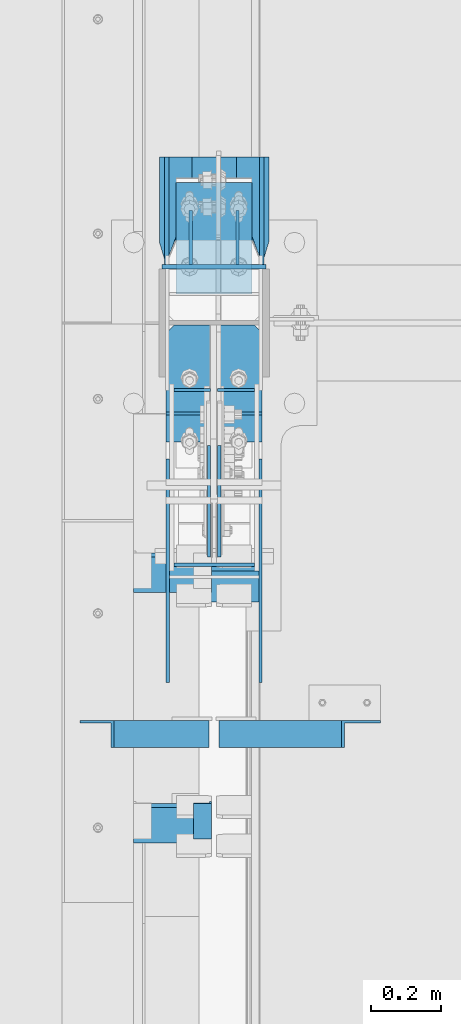
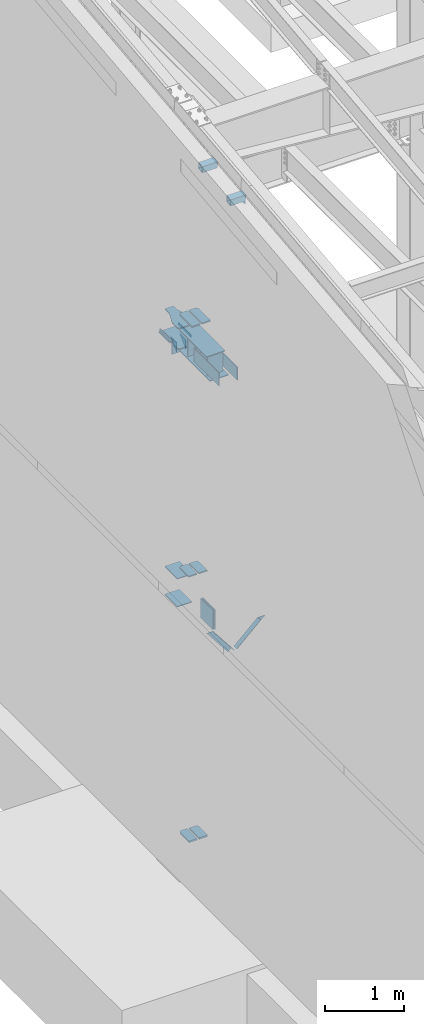
# One storey, part 827 of 1179: 27 beams, 2 members, 13 elements without a shape of their own.
"""IFC2X3 building model written with IfcOpenShell, lengths in millimetres."""

from ifc_helpers import new_model, si_unit, frame, origin_with_axes, place, context, subcontext, project, spatial, faceted_brep, material, type_object, element, aggregate, save


model = new_model("IFC2X3")

# Units and contexts
model_context = context("Model", 3, precision=1e-05, world=origin_with_axes())
body_context = subcontext(model_context, "Body", "Model", "MODEL_VIEW")
ifc_project = project(units=[si_unit("LENGTHUNIT", "METRE", prefix="MILLI"), si_unit("AREAUNIT", "SQUARE_METRE"), si_unit("VOLUMEUNIT", "CUBIC_METRE"), si_unit("MASSUNIT", "GRAM", prefix="KILO"), si_unit("TIMEUNIT", "SECOND"), si_unit("PLANEANGLEUNIT", "RADIAN"), si_unit("SOLIDANGLEUNIT", "STERADIAN"), si_unit("THERMODYNAMICTEMPERATUREUNIT", "DEGREE_CELSIUS"), si_unit("LUMINOUSINTENSITYUNIT", "LUMEN")], contexts=[model_context])

# Site, building, storey
site_placement = place(None, origin_with_axes())
site = spatial("IfcSite", under=ifc_project, at=site_placement, CompositionType="ELEMENT")
building_placement = place(site_placement, origin_with_axes())
building = spatial("IfcBuilding", under=site, at=building_placement, Name="Undefined", CompositionType="ELEMENT")
storey_placement = place(building_placement, origin_with_axes())
storey = spatial("IfcBuildingStorey", under=building, at=storey_placement, Name="Undefined", CompositionType="ELEMENT", Elevation=0.0)

# Assembly, member
assembly_1_placement = place(storey_placement, origin_with_axes())
assembly_1 = element("IfcElementAssembly", 1, at=assembly_1_placement, inside=storey, Name="ANGLE", AssemblyPlace="NOTDEFINED", PredefinedType="RIGID_FRAME")
ifc_material_1 = material(Name="STEEL/A36")
member_type = type_object("IfcMemberType", Name="L3X3X1/4", PredefinedType="NOTDEFINED")
member_1_placement = place(assembly_1_placement, frame((472.414639168564, 18059.4, 3736.19330123132), z_axis=(0.0, -1.0, 0.0), x_axis=(0.729484494811633, 0.0, 0.683997347823379)))
member_1 = element("IfcMember", 2, at=member_1_placement, type_object=member_type, material=ifc_material_1, Name="ANGLE", ObjectType="L3X3X1/4", context=body_context, shape_type="Brep", body=[
    faceted_brep([(0.0, 38.0999999999985, -38.0999999999999), (0.0, 38.0999999999985, 38.0999999999999), (475.752341075195, 38.0999999999181, 38.1000000000004), (475.752341075195, 38.0999999999181, -38.1000000000004), (0.0, 31.75, 38.1000000000004), (482.524628360803, 31.7499999999177, 38.1000000000004), (0.0, 31.75, -31.75), (482.524628360803, 31.7499999999177, -31.75), (0.0, -38.0999999999985, -31.75), (557.019788502486, -38.1000000000854, -31.75), (0.0, -38.0999999999985, -38.0999999999999), (557.019788502486, -38.1000000000854, -38.1000000000004)], [[[0, 1, 2, 3]], [[1, 4, 5, 2]], [[4, 6, 7, 5]], [[6, 8, 9, 7]], [[8, 10, 11, 9]], [[10, 0, 3, 11]], [[5, 7, 9, 11, 3, 2]], [[10, 8, 6, 4, 1, 0]]]),
])
aggregate(assembly_1, [member_1])

assembly_2_placement = place(storey_placement, origin_with_axes())
assembly_2 = element("IfcElementAssembly", 3, at=assembly_2_placement, inside=storey, Name="ANGLE", AssemblyPlace="NOTDEFINED", PredefinedType="RIGID_FRAME")
member_2_placement = place(assembly_2_placement, frame((80.8196258456476, 18059.4, 4125.56128839178), z_axis=(0.0, -1.0, 0.0), x_axis=(0.614083067285056, 0.0, -0.789241399366364)))
member_2 = element("IfcMember", 4, at=member_2_placement, type_object=member_type, material=ifc_material_1, Name="ANGLE", ObjectType="L3X3X1/4", context=body_context, shape_type="Brep", body=[
    faceted_brep([(59.3707492954454, 38.0999999999781, -38.1000000000004), (59.3707492954454, 38.0999999999781, 38.1000000000004), (499.083854779058, 38.0999999998585, 38.1000000000004), (499.083854779058, 38.0999999998585, -38.1000000000004), (54.4300207928691, 31.7499999999804, 38.1000000000004), (499.083854779056, 31.7499999998595, 38.1000000000004), (54.4300207928691, 31.7499999999804, -31.75), (499.083854779056, 31.7499999998595, -31.75), (0.0820072645328764, -38.0999999999945, -31.75), (499.083854779043, -38.10000000013, -31.75), (0.0820072645328764, -38.0999999999945, -38.1000000000004), (499.083854779043, -38.10000000013, -38.1000000000004)], [[[0, 1, 2, 3]], [[1, 4, 5, 2]], [[4, 6, 7, 5]], [[6, 8, 9, 7]], [[8, 10, 11, 9]], [[10, 0, 3, 11]], [[5, 7, 9, 11, 3, 2]], [[10, 8, 6, 4, 1, 0]]]),
])
aggregate(assembly_2, [member_2])

# Assembly, beams
assembly_3_placement = place(storey_placement, origin_with_axes())
assembly_3 = element("IfcElementAssembly", 5, at=assembly_3_placement, inside=storey, Name="COLUMN", AssemblyPlace="NOTDEFINED", PredefinedType="RIGID_FRAME")
beam_type_1 = type_object("IfcBeamType", PredefinedType="NOTDEFINED")
beam_1_placement = place(assembly_3_placement, frame((284.162500000006, 19388.1375, 7616.82500000912), z_axis=(0.0, 0.0, 1.0), x_axis=(1.0, 0.0, 0.0)))
beam_1 = element("IfcBeam", 6, at=beam_1_placement, type_object=beam_type_1, material=ifc_material_1, Name="PLATE", context=body_context, shape_type="Brep", body=[
    faceted_brep([(-7.27595761418343e-12, 6.35000000000036, -76.1999999999971), (0.0, 6.35000000000036, 76.2000000000044), (295.274999999994, 6.34999999999854, 76.2000000000007), (295.274999999994, 6.34999999999854, -76.2000000000007), (0.0, -6.35000000000036, 76.2000000000044), (295.274999999994, -6.34999999999854, 76.2000000000007), (7.27595761418343e-12, -6.35000000000036, -76.1999999999971), (295.274999999994, -6.34999999999854, -76.2000000000007)], [[[0, 1, 2, 3]], [[1, 4, 5, 2]], [[4, 6, 7, 5]], [[6, 0, 3, 7]], [[5, 7, 3, 2]], [[6, 4, 1, 0]]]),
])
ifc_material_2 = material(Name="STEEL/A572-GR.50")
beam_type_2 = type_object("IfcBeamType", PredefinedType="NOTDEFINED")
beam_2_placement = place(assembly_3_placement, frame((505.619000000002, 18974.0139016459, 4353.49928057188), z_axis=(1.0, 0.0, 0.0), x_axis=(0.0, 1.0, 0.0)))
beam_2 = element("IfcBeam", 7, at=beam_2_placement, type_object=beam_type_2, material=ifc_material_2, Name="PLATE", context=body_context, shape_type="Brep", body=[
    faceted_brep([(247.436098354521, -9.52499999999964, 40.4809996181785), (247.436098354145, 9.52499999999964, 40.4809996181785), (225.211098339509, 9.52499999999964, 62.7065000000002), (225.211098339509, -9.52499999999964, 62.7065000000002), (6.18456397205591e-11, -9.52499999999964, -62.7065000000084), (0.0, -9.52499999999964, 62.7065000000002), (0.0, 9.52499999999964, 62.7065000000002), (6.18456397205591e-11, 9.52499999999964, -62.7065000000084), (247.436098339509, 9.52499999999964, -62.7065000000002), (247.436098339509, -9.52499999999964, -62.7065000000002)], [[[0, 1, 2, 3]], [[4, 5, 6, 7]], [[4, 7, 8, 9]], [[5, 4, 9, 0, 3]], [[6, 5, 3, 2]], [[8, 7, 6, 2, 1]], [[9, 8, 1, 0]]]),
])
beam_3_placement = place(assembly_3_placement, frame((357.981000000002, 18974.0139016459, 4353.49928057188), z_axis=(-1.0, 0.0, 0.0), x_axis=(0.0, 1.0, 0.0)))
beam_3 = element("IfcBeam", 8, at=beam_3_placement, type_object=beam_type_2, material=ifc_material_2, Name="PLATE", context=body_context, shape_type="Brep", body=[
    faceted_brep([(247.436098354521, -9.52499999999964, 40.4809996181785), (247.436098354145, 9.52499999999964, 40.4809996181785), (225.211098339509, 9.52499999999964, 62.7065000000002), (225.211098339509, -9.52499999999964, 62.7065000000002), (6.18456397205591e-11, -9.52499999999964, -62.7065000000084), (0.0, -9.52499999999964, 62.7065000000002), (0.0, 9.52499999999964, 62.7065000000002), (6.18456397205591e-11, 9.52499999999964, -62.7065000000084), (247.436098339509, 9.52499999999964, -62.7065000000002), (247.436098339509, -9.52499999999964, -62.7065000000002)], [[[0, 1, 2, 3]], [[4, 5, 6, 7]], [[4, 7, 8, 9]], [[5, 4, 9, 0, 3]], [[6, 5, 3, 2]], [[8, 7, 6, 2, 1]], [[9, 8, 1, 0]]]),
])
beam_type_3 = type_object("IfcBeamType", PredefinedType="NOTDEFINED")
beam_4_placement = place(assembly_3_placement, frame((431.800000000001, 19310.35, 3676.65), z_axis=(1.0, 0.0, 0.0), x_axis=(0.0, 1.0, 0.0)))
beam_4 = element("IfcBeam", 9, at=beam_4_placement, type_object=beam_type_3, material=ifc_material_2, Name="PLATE", context=body_context, shape_type="Brep", body=[
    faceted_brep([(0.0, 6.35000000000036, -107.949999999997), (0.0, 6.35000000000036, 107.949999999997), (317.5, 6.35000000000036, 107.949999999997), (317.5, 6.35000000000036, -107.949999999997), (0.0, -6.35000000000036, 107.949999999997), (317.5, -6.35000000000036, 107.949999999997), (0.0, -6.35000000000036, -107.949999999997), (317.5, -6.35000000000036, -107.949999999997)], [[[0, 1, 2, 3]], [[1, 4, 5, 2]], [[4, 6, 7, 5]], [[6, 0, 3, 7]], [[5, 7, 3, 2]], [[6, 4, 1, 0]]]),
])
beam_5_placement = place(assembly_3_placement, frame((431.800000000001, 19310.35, 4108.45), z_axis=(1.0, 0.0, 0.0), x_axis=(0.0, 1.0, 0.0)))
beam_5 = element("IfcBeam", 10, at=beam_5_placement, type_object=beam_type_3, material=ifc_material_2, Name="PLATE", context=body_context, shape_type="Brep", body=[
    faceted_brep([(0.0, 6.35000000000036, -107.949999999997), (0.0, 6.35000000000036, 107.949999999997), (317.5, 6.35000000000036, 107.949999999997), (317.5, 6.35000000000036, -107.949999999997), (0.0, -6.35000000000036, 107.949999999997), (317.5, -6.35000000000036, 107.949999999997), (0.0, -6.35000000000036, -107.949999999997), (317.5, -6.35000000000036, -107.949999999997)], [[[0, 1, 2, 3]], [[1, 4, 5, 2]], [[4, 6, 7, 5]], [[6, 0, 3, 7]], [[5, 7, 3, 2]], [[6, 4, 1, 0]]]),
])

# Assembly, beam
assembly_4_placement = place(storey_placement, origin_with_axes())
assembly_4 = element("IfcElementAssembly", 11, at=assembly_4_placement, inside=storey, Name="BEAM", AssemblyPlace="NOTDEFINED", PredefinedType="RIGID_FRAME")
beam_type_4 = type_object("IfcBeamType", Name="L2X2X1/4", PredefinedType="NOTDEFINED")
beam_6_placement = place(assembly_4_placement, frame((399.256249999966, 17864.9694884529, 10830.0669268878), z_axis=(-1.0, 0.0, 0.0), x_axis=(0.0, -0.993676146336441, -0.112284087038017)))
beam_6 = element("IfcBeam", 12, at=beam_6_placement, type_object=beam_type_4, material=ifc_material_1, Name="ANGLE", ObjectType="L2X2X1/4", context=body_context, shape_type="Brep", body=[
    faceted_brep([(0.0, 25.3999999999996, -25.4000000000015), (0.0, 25.3999999999996, 25.4000000000015), (101.599999999555, 25.4, 25.3999999999451), (101.599999999537, 25.4, -25.4000000000251), (7.27595761418343e-12, 19.05, 25.3999999999851), (101.599999999555, 19.05, 25.3999999999451), (0.0, 19.0499992350015, -19.0499992349996), (101.600003324515, 19.0499992350051, -19.0499992350015), (-1.09139364212751e-11, -25.4, -19.0499999999865), (101.59999999954, -25.4, -19.0500000000302), (0.0, -25.3999999999996, -25.4000000000015), (101.599999999537, -25.4, -25.4000000000251)], [[[0, 1, 2, 3]], [[1, 4, 5, 2]], [[4, 6, 7, 5]], [[6, 8, 9, 7]], [[8, 10, 11, 9]], [[10, 0, 3, 11]], [[5, 7, 9, 11, 3, 2]], [[10, 8, 6, 4, 1, 0]]]),
])
aggregate(assembly_4, [beam_6])

# Beam
beam_type_5 = type_object("IfcBeamType", PredefinedType="NOTDEFINED")
beam_7_placement = place(assembly_3_placement, frame((358.775000000002, 18888.9023695225, 8262.24369604468), z_axis=(-1.0, 0.0, 0.0), x_axis=(0.0, 1.0, 0.0)))
beam_7 = element("IfcBeam", 13, at=beam_7_placement, type_object=beam_type_5, material=ifc_material_2, Name="PLATE", context=body_context, shape_type="Brep", body=[
    faceted_brep([(332.547630477533, 9.52499999999964, 41.2750000000015), (310.322630477534, 9.52499999999964, 63.5), (310.322630477534, -9.52499999999964, 63.5), (332.547630477533, -9.52499999999964, 41.2750000000015), (332.547630477533, 9.52499999999964, -63.5), (0.0, 9.52500000000146, -63.5), (0.0, 9.52500000000146, 63.5), (0.0, -9.52500000000146, 63.5), (0.0, -9.52500000000146, -63.5), (332.547630477533, -9.52499999999964, -63.5)], [[[0, 1, 2, 3]], [[4, 5, 6, 1, 0]], [[6, 7, 2, 1]], [[7, 8, 9, 3, 2]], [[8, 5, 4, 9]], [[9, 4, 0, 3]], [[8, 7, 6, 5]]]),
])

beam_8_placement = place(assembly_3_placement, frame((504.825000000002, 18888.9023695225, 8262.24369604468), z_axis=(-1.0, 0.0, 0.0), x_axis=(0.0, 1.0, 0.0)))
beam_8 = element("IfcBeam", 14, at=beam_8_placement, type_object=beam_type_5, material=ifc_material_2, Name="PLATE", context=body_context, shape_type="Brep", body=[
    faceted_brep([(310.322630477534, 9.52499999999964, -63.5), (332.547630477533, 9.52499999999964, -41.2750000000015), (332.547630477533, -9.52499999999964, -41.2750000000015), (310.322630477534, -9.52499999999964, -63.5), (0.0, 9.52500000000146, -63.5), (0.0, 9.52500000000146, 63.5), (332.547630477533, 9.52499999999964, 63.5), (0.0, -9.52500000000146, 63.5), (332.547630477533, -9.52499999999964, 63.5), (0.0, -9.52500000000146, -63.5)], [[[0, 1, 2, 3]], [[4, 5, 6, 1, 0]], [[5, 7, 8, 6]], [[8, 7, 9, 3, 2]], [[9, 4, 0, 3]], [[6, 8, 2, 1]], [[9, 7, 5, 4]]]),
])

# Assembly, beam
assembly_5_placement = place(storey_placement, origin_with_axes())
assembly_5 = element("IfcElementAssembly", 15, at=assembly_5_placement, inside=storey, Name="PLATE", AssemblyPlace="NOTDEFINED", PredefinedType="RIGID_FRAME")
beam_type_6 = type_object("IfcBeamType", PredefinedType="NOTDEFINED")
beam_9_placement = place(assembly_5_placement, frame((563.562500000004, 18840.6248035139, 7861.3), z_axis=(0.0, 0.0, 1.0), x_axis=(0.0, -1.0, 0.0)))
beam_9 = element("IfcBeam", 16, at=beam_9_placement, type_object=beam_type_6, material=ifc_material_2, Name="PLATE", context=body_context, shape_type="Brep", body=[
    faceted_brep([(0.0, 4.76250000000073, -101.6), (0.0, 4.76250000000073, 101.6), (635.0, 4.76250000000073, 101.6), (635.0, 4.76250000000073, -101.6), (0.0, -4.76250000000073, 101.6), (635.0, -4.76250000000073, 101.6), (0.0, -4.76250000000073, -101.6), (635.0, -4.76250000000073, -101.6)], [[[0, 1, 2, 3]], [[1, 4, 5, 2]], [[4, 6, 7, 5]], [[6, 0, 3, 7]], [[5, 7, 3, 2]], [[6, 4, 1, 0]]]),
])
aggregate(assembly_5, [beam_9])

assembly_6_placement = place(storey_placement, origin_with_axes())
assembly_6 = element("IfcElementAssembly", 17, at=assembly_6_placement, inside=storey, Name="PLATE", AssemblyPlace="NOTDEFINED", PredefinedType="RIGID_FRAME")
beam_10_placement = place(assembly_6_placement, frame((300.037500000002, 18840.6248035139, 7861.3), z_axis=(0.0, 0.0, 1.0), x_axis=(0.0, -1.0, 0.0)))
beam_10 = element("IfcBeam", 18, at=beam_10_placement, type_object=beam_type_6, material=ifc_material_2, Name="PLATE", context=body_context, shape_type="Brep", body=[
    faceted_brep([(0.0, 4.76250000000073, -101.6), (0.0, 4.76250000000073, 101.6), (635.0, 4.76250000000073, 101.6), (635.0, 4.76250000000073, -101.6), (0.0, -4.76250000000073, 101.6), (635.0, -4.76250000000073, 101.6), (0.0, -4.76250000000073, -101.6), (635.0, -4.76250000000073, -101.6)], [[[0, 1, 2, 3]], [[1, 4, 5, 2]], [[4, 6, 7, 5]], [[6, 0, 3, 7]], [[5, 7, 3, 2]], [[6, 4, 1, 0]]]),
])
aggregate(assembly_6, [beam_10])

# Beam
beam_type_7 = type_object("IfcBeamType", PredefinedType="NOTDEFINED")
beam_11_placement = place(assembly_3_placement, frame((317.5, 18540.5873035139, 7861.3), z_axis=(0.0, 0.0, 1.0), x_axis=(1.0, 0.0, 0.0)))
beam_11 = element("IfcBeam", 19, at=beam_11_placement, type_object=beam_type_7, material=ifc_material_2, Name="PLATE", context=body_context, shape_type="Brep", body=[
    faceted_brep([(0.0, 4.76250000000073, -152.4), (0.0, 4.76250000000073, 152.4), (228.600000000002, 4.76250000000073, 152.4), (228.600000000002, 4.76250000000073, -152.4), (0.0, -4.76250000000073, 152.4), (228.600000000002, -4.76250000000073, 152.4), (0.0, -4.76250000000073, -152.4), (228.600000000002, -4.76250000000073, -152.4)], [[[0, 1, 2, 3]], [[1, 4, 5, 2]], [[4, 6, 7, 5]], [[6, 0, 3, 7]], [[5, 7, 3, 2]], [[6, 4, 1, 0]]]),
])

beam_type_8 = type_object("IfcBeamType", PredefinedType="NOTDEFINED")
beam_12_placement = place(assembly_3_placement, frame((441.325000000002, 19037.3, 7861.3), z_axis=(0.0, 0.0, 1.0), x_axis=(1.0, 0.0, 0.0)))
beam_12 = element("IfcBeam", 20, at=beam_12_placement, type_object=beam_type_8, material=ifc_material_2, Name="PLATE", context=body_context, shape_type="Brep", body=[
    faceted_brep([(0.0, 4.76250000000073, -152.4), (0.0, 4.76250000000073, 152.4), (104.775000000001, 4.76250000000073, 152.4), (104.775000000001, 4.76250000000073, -152.4), (0.0, -4.76250000000073, 152.4), (104.775000000001, -4.76250000000073, 152.4), (0.0, -4.76250000000073, -152.4), (104.775000000001, -4.76250000000073, -152.4)], [[[0, 1, 2, 3]], [[1, 4, 5, 2]], [[4, 6, 7, 5]], [[6, 0, 3, 7]], [[5, 7, 3, 2]], [[6, 4, 1, 0]]]),
])

beam_13_placement = place(assembly_3_placement, frame((317.500000000001, 19037.3, 7861.3), z_axis=(0.0, 0.0, 1.0), x_axis=(1.0, 0.0, 0.0)))
beam_13 = element("IfcBeam", 21, at=beam_13_placement, type_object=beam_type_8, material=ifc_material_2, Name="PLATE", context=body_context, shape_type="Brep", body=[
    faceted_brep([(0.0, 4.76250000000073, -152.4), (0.0, 4.76250000000073, 152.4), (104.775000000001, 4.76250000000073, 152.4), (104.775000000001, 4.76250000000073, -152.4), (0.0, -4.76250000000073, 152.4), (104.775000000001, -4.76250000000073, 152.4), (0.0, -4.76250000000073, -152.4), (104.775000000001, -4.76250000000073, -152.4)], [[[0, 1, 2, 3]], [[1, 4, 5, 2]], [[4, 6, 7, 5]], [[6, 0, 3, 7]], [[5, 7, 3, 2]], [[6, 4, 1, 0]]]),
])

beam_type_9 = type_object("IfcBeamType", PredefinedType="NOTDEFINED")
beam_14_placement = place(assembly_3_placement, frame((431.799999999999, 18434.2248035139, 7702.55), z_axis=(-1.0, 0.0, 0.0), x_axis=(0.0, 1.0, 0.0)))
beam_14 = element("IfcBeam", 22, at=beam_14_placement, type_object=beam_type_9, material=ifc_material_2, Name="PLATE", context=body_context, shape_type="Brep", body=[
    faceted_brep([(765.000197461464, 6.35000000000036, -136.525000000001), (787.225197461465, 6.35000000000036, -114.299999999999), (787.225197461465, -6.35000000000036, -114.299999999999), (765.000197461464, -6.35000000000036, -136.525000000001), (787.225197461465, 6.35000000000036, 114.299999999999), (765.000197461464, 6.35000000000036, 136.525000000001), (765.000197461464, -6.35000000000036, 136.525000000001), (787.225197461465, -6.35000000000036, 114.299999999999), (0.0, 6.35000000000036, -136.525000000001), (0.0, 6.35000000000036, 136.525000000001), (0.0, -6.35000000000036, 136.525000000001), (0.0, -6.35000000000036, -136.525000000001)], [[[0, 1, 2, 3]], [[4, 5, 6, 7]], [[8, 9, 5, 4, 1, 0]], [[9, 10, 6, 5]], [[7, 6, 10, 11, 3, 2]], [[11, 8, 0, 3]], [[4, 7, 2, 1]], [[11, 10, 9, 8]]]),
])

beam_15_placement = place(assembly_3_placement, frame((431.799999999999, 18523.1248035139, 8020.05), z_axis=(-1.0, 0.0, 0.0), x_axis=(0.0, 1.0, 0.0)))
beam_15 = element("IfcBeam", 23, at=beam_15_placement, type_object=beam_type_9, material=ifc_material_2, Name="PLATE", context=body_context, shape_type="Brep", body=[
    faceted_brep([(676.100197461472, 6.35000000000036, -136.525000000001), (698.325197461472, 6.35000000000036, -114.299999999999), (698.325197461472, -6.35000000000036, -114.299999999999), (676.100197461472, -6.35000000000036, -136.525000000001), (698.325197461472, 6.35000000000036, 114.299999999999), (676.100197461472, 6.35000000000036, 136.525000000001), (676.100197461472, -6.35000000000036, 136.525000000001), (698.325197461472, -6.35000000000036, 114.299999999999), (0.0, 6.35000000000036, -136.525000000001), (0.0, 6.35000000000036, 136.525000000001), (0.0, -6.35000000000036, 136.525000000001), (0.0, -6.35000000000036, -136.525000000001)], [[[0, 1, 2, 3]], [[4, 5, 6, 7]], [[8, 9, 5, 4, 1, 0]], [[9, 10, 6, 5]], [[7, 6, 10, 11, 3, 2]], [[11, 8, 0, 3]], [[4, 7, 2, 1]], [[11, 10, 9, 8]]]),
])

# Assembly, beam
assembly_7_placement = place(storey_placement, origin_with_axes())
assembly_7 = element("IfcElementAssembly", 24, at=assembly_7_placement, inside=storey, Name="PLATE", AssemblyPlace="NOTDEFINED", PredefinedType="RIGID_FRAME")
beam_type_10 = type_object("IfcBeamType", PredefinedType="NOTDEFINED")
beam_16_placement = place(assembly_7_placement, frame((356.3935, 18966.3380811392, 267.318748335632), z_axis=(-1.0, 0.0, 0.0), x_axis=(0.0, 1.0, 0.0)))
beam_16 = element("IfcBeam", 25, at=beam_16_placement, type_object=beam_type_10, material=ifc_material_2, Name="PLATE", context=body_context, shape_type="Brep", body=[
    faceted_brep([(255.111918860846, 12.7, 38.8940000000002), (232.886918860846, 12.7, 61.1189999999988), (232.886918860846, -12.7, 61.1189999999988), (255.111918860846, -12.7, 38.8940000000002), (255.111918860846, 12.7, -61.1189999999988), (0.0, 12.7, -61.1189999999988), (0.0, 12.7, 61.1189999999988), (0.0, -12.7, 61.1189999999988), (0.0, -12.7, -61.1189999999988), (255.111918860846, -12.7, -61.1189999999988)], [[[0, 1, 2, 3]], [[4, 5, 6, 1, 0]], [[6, 7, 2, 1]], [[7, 8, 9, 3, 2]], [[8, 5, 4, 9]], [[9, 4, 0, 3]], [[8, 7, 6, 5]]]),
])
aggregate(assembly_7, [beam_16])

assembly_8_placement = place(storey_placement, origin_with_axes())
assembly_8 = element("IfcElementAssembly", 26, at=assembly_8_placement, inside=storey, Name="PLATE", AssemblyPlace="NOTDEFINED", PredefinedType="RIGID_FRAME")
beam_17_placement = place(assembly_8_placement, frame((507.2065, 18966.3380811392, 267.318748335632), z_axis=(1.0, 0.0, 0.0), x_axis=(0.0, 1.0, 0.0)))
beam_17 = element("IfcBeam", 27, at=beam_17_placement, type_object=beam_type_10, material=ifc_material_2, Name="PLATE", context=body_context, shape_type="Brep", body=[
    faceted_brep([(255.111918860846, 12.7, 38.8940000000002), (232.886918860846, 12.7, 61.1189999999988), (232.886918860846, -12.7, 61.1189999999988), (255.111918860846, -12.7, 38.8940000000002), (255.111918860846, 12.7, -61.1189999999988), (0.0, 12.7, -61.1189999999988), (0.0, 12.7, 61.1189999999988), (0.0, -12.7, 61.1189999999988), (0.0, -12.7, -61.1189999999988), (255.111918860846, -12.7, -61.1189999999988)], [[[0, 1, 2, 3]], [[4, 5, 6, 1, 0]], [[6, 7, 2, 1]], [[7, 8, 9, 3, 2]], [[8, 5, 4, 9]], [[9, 4, 0, 3]], [[8, 7, 6, 5]]]),
])
aggregate(assembly_8, [beam_17])

assembly_9_placement = place(storey_placement, origin_with_axes())
assembly_9 = element("IfcElementAssembly", 28, at=assembly_9_placement, inside=storey, Name="PLATE", AssemblyPlace="NOTDEFINED", PredefinedType="RIGID_FRAME")
beam_type_11 = type_object("IfcBeamType", PredefinedType="NOTDEFINED")
beam_18_placement = place(assembly_9_placement, frame((417.512500000002, 18562.3008203787, 3892.55), z_axis=(0.0, 0.0, -1.0), x_axis=(0.0, 1.0, 0.0)))
beam_18 = element("IfcBeam", 29, at=beam_18_placement, type_object=beam_type_11, material=ifc_material_2, Name="PLATE", context=body_context, shape_type="Brep", body=[
    faceted_brep([(0.0, 4.76250000000073, -152.4), (0.0, 4.76250000000073, 152.4), (317.5, 4.76250000000073, 152.4), (317.5, 4.76250000000073, -152.4), (0.0, -4.76250000000073, 152.4), (317.5, -4.76250000000073, 152.4), (0.0, -4.76250000000073, -152.4), (317.5, -4.76250000000073, -152.4)], [[[0, 1, 2, 3]], [[1, 4, 5, 2]], [[4, 6, 7, 5]], [[6, 0, 3, 7]], [[5, 7, 3, 2]], [[6, 4, 1, 0]]]),
])
aggregate(assembly_9, [beam_18])

assembly_10_placement = place(storey_placement, origin_with_axes())
assembly_10 = element("IfcElementAssembly", 30, at=assembly_10_placement, inside=storey, Name="PLATE", AssemblyPlace="NOTDEFINED", PredefinedType="RIGID_FRAME")
beam_19_placement = place(assembly_10_placement, frame((446.087213611823, 18879.8008203787, 3892.55), z_axis=(0.0, 0.0, -1.0), x_axis=(0.0, -1.0, 0.0)))
beam_19 = element("IfcBeam", 31, at=beam_19_placement, type_object=beam_type_11, material=ifc_material_2, Name="PLATE", context=body_context, shape_type="Brep", body=[
    faceted_brep([(0.0, 4.76250000000073, -152.4), (0.0, 4.76250000000073, 152.4), (317.5, 4.76250000000073, 152.4), (317.5, 4.76250000000073, -152.4), (0.0, -4.76250000000073, 152.4), (317.5, -4.76250000000073, 152.4), (0.0, -4.76250000000073, -152.4), (317.5, -4.76250000000073, -152.4)], [[[0, 1, 2, 3]], [[1, 4, 5, 2]], [[4, 6, 7, 5]], [[6, 0, 3, 7]], [[5, 7, 3, 2]], [[6, 4, 1, 0]]]),
])
aggregate(assembly_10, [beam_19])

# Beam
beam_type_12 = type_object("IfcBeamType", PredefinedType="NOTDEFINED")
beam_20_placement = place(assembly_3_placement, frame((296.862500000007, 19699.2875, 7727.95000000912), z_axis=(0.0, 0.0, 1.0), x_axis=(0.0, -1.0, 0.0)))
beam_20 = element("IfcBeam", 32, at=beam_20_placement, type_object=beam_type_12, material=ifc_material_1, Name="PLATE", context=body_context, shape_type="Brep", body=[
    faceted_brep([(0.0, 6.34999999999854, -19.0499999999993), (0.0, 6.35000000000036, 19.0499999999993), (317.5, 6.34999999999854, 19.0499999999993), (317.5, 6.34999999999854, -19.0499999999993), (0.0, -6.35000000000036, 19.0499999999993), (317.5, -6.34999999999854, 19.0499999999993), (0.0, -6.34999999999854, -19.0499999999993), (317.5, -6.34999999999854, -19.0499999999993)], [[[0, 1, 2, 3]], [[1, 4, 5, 2]], [[4, 6, 7, 5]], [[6, 0, 3, 7]], [[5, 7, 3, 2]], [[6, 4, 1, 0]]]),
])

beam_21_placement = place(assembly_3_placement, frame((566.737500000003, 19699.2875, 7727.95000000912), z_axis=(0.0, 0.0, 1.0), x_axis=(0.0, -1.0, 0.0)))
beam_21 = element("IfcBeam", 33, at=beam_21_placement, type_object=beam_type_12, material=ifc_material_1, Name="PLATE", context=body_context, shape_type="Brep", body=[
    faceted_brep([(0.0, 6.34999999999854, -19.0499999999993), (0.0, 6.35000000000036, 19.0499999999993), (317.5, 6.34999999999854, 19.0499999999993), (317.5, 6.34999999999854, -19.0499999999993), (0.0, -6.35000000000036, 19.0499999999993), (317.5, -6.34999999999854, 19.0499999999993), (0.0, -6.34999999999854, -19.0499999999993), (317.5, -6.34999999999854, -19.0499999999993)], [[[0, 1, 2, 3]], [[1, 4, 5, 2]], [[4, 6, 7, 5]], [[6, 0, 3, 7]], [[5, 7, 3, 2]], [[6, 4, 1, 0]]]),
])

beam_type_13 = type_object("IfcBeamType", PredefinedType="NOTDEFINED")
beam_22_placement = place(assembly_3_placement, frame((365.125000000004, 19546.8875, 7616.82500000912), z_axis=(0.0, 0.0, 1.0), x_axis=(0.0, -1.0, 0.0)))
beam_22 = element("IfcBeam", 34, at=beam_22_placement, type_object=beam_type_13, material=ifc_material_1, Name="PLATE", context=body_context, shape_type="Brep", body=[
    faceted_brep([(152.4, -4.76249999999709, 76.2), (152.4, -4.76249999999709, -76.2), (152.4, 4.76249999999709, -76.2), (152.4, 4.76249999999709, 76.2), (0.0, 4.76249999999982, 76.1999999999971), (0.0, -4.76249999999982, 76.1999999999971)], [[[0, 1, 2, 3]], [[3, 2, 4]], [[4, 5, 0, 3]], [[0, 5, 1]], [[4, 2, 1, 5]]]),
])

beam_23_placement = place(assembly_3_placement, frame((498.475000000002, 19546.8875, 7616.82500000912), z_axis=(0.0, 0.0, 1.0), x_axis=(0.0, -1.0, 0.0)))
beam_23 = element("IfcBeam", 35, at=beam_23_placement, type_object=beam_type_13, material=ifc_material_1, Name="PLATE", context=body_context, shape_type="Brep", body=[
    faceted_brep([(152.4, -4.76249999999709, 76.2), (152.4, -4.76249999999709, -76.2), (152.4, 4.76249999999709, -76.2), (152.4, 4.76249999999709, 76.2), (0.0, 4.76249999999982, 76.1999999999971), (0.0, -4.76249999999982, 76.1999999999971)], [[[0, 1, 2, 3]], [[3, 2, 4]], [[4, 5, 0, 3]], [[0, 5, 1]], [[4, 2, 1, 5]]]),
])

beam_type_14 = type_object("IfcBeamType", PredefinedType="NOTDEFINED")
beam_24_placement = place(assembly_3_placement, frame((431.800000000003, 19699.2875, 7700.96250000912), z_axis=(1.0, 0.0, 0.0), x_axis=(0.0, -1.0, 0.0)))
beam_24 = element("IfcBeam", 36, at=beam_24_placement, type_object=beam_type_14, material=ifc_material_1, Name="PLATE", context=body_context, shape_type="Brep", body=[
    faceted_brep([(465.137499999997, -7.9375, -114.300000762945), (442.912499999999, -7.9375, -136.525000762944), (442.912500000006, 7.9375, -136.525000762944), (465.137500000004, 7.9375, -114.300000762945), (465.137500000004, 7.9375, 114.300000762938), (442.912500000006, 7.9375, 136.525000762937), (442.912499999999, -7.9375, 136.525000762937), (465.137499999997, -7.9375, 114.300000762938), (241.300006103491, -7.9375, -155.575000000001), (241.300006103491, 7.9375, -155.575000000001), (304.799990844724, 7.9375, -136.525000762944), (304.799990844724, -7.9375, -136.525000762944), (0.0, -7.9375, -155.575000000001), (0.0, -7.9375, 155.575000000001), (0.0, 7.9375, 155.575000000001), (0.0, 7.9375, -155.575000000001), (241.300006103513, -7.9375, 155.575000000001), (241.300006103513, 7.9375, 155.575000000001), (304.799990844724, -7.9375, 136.525000762937), (304.799990844724, 7.9375, 136.525000762937)], [[[0, 1, 2, 3]], [[4, 5, 6, 7]], [[8, 9, 10, 11]], [[11, 10, 2, 1]], [[12, 13, 14, 15]], [[14, 13, 16, 17]], [[18, 19, 17, 16]], [[19, 18, 6, 5]], [[4, 7, 0, 3]], [[10, 9, 15, 14, 17, 19, 5, 4, 3, 2]], [[12, 15, 9, 8]], [[7, 6, 18, 16, 13, 12, 8, 11, 1, 0]]]),
])

aggregate(assembly_3, [beam_7, beam_8, beam_12, beam_13, beam_11, beam_14, beam_15, beam_2, beam_3, beam_20, beam_22, beam_21, beam_23, beam_24, beam_1, beam_4, beam_5])

# Assembly, beam
assembly_11_placement = place(storey_placement, origin_with_axes())
assembly_11 = element("IfcElementAssembly", 37, at=assembly_11_placement, inside=storey, Name="PLATE", AssemblyPlace="NOTDEFINED", PredefinedType="RIGID_FRAME")
beam_type_15 = type_object("IfcBeamType", PredefinedType="NOTDEFINED")
beam_25_placement = place(assembly_11_placement, frame((431.800000000003, 19699.2875, 8021.63750000912), z_axis=(1.0, 0.0, 0.0), x_axis=(0.0, -1.0, 0.0)))
beam_25 = element("IfcBeam", 38, at=beam_25_placement, type_object=beam_type_15, material=ifc_material_1, Name="PLATE", context=body_context, shape_type="Brep", body=[
    faceted_brep([(465.137499999997, -7.9375, -114.300000762945), (442.912499999999, -7.9375, -136.525000762944), (442.912500000006, 7.9375, -136.525000762944), (465.137500000004, 7.9375, -114.300000762945), (465.137500000004, 7.9375, 114.300000762938), (442.912500000006, 7.9375, 136.525000762937), (442.912499999999, -7.9375, 136.525000762937), (465.137499999997, -7.9375, 114.300000762938), (97.1744871646697, -7.9375, 63.4999984741225), (97.1744871646697, 7.9375, 63.4999984741225), (0.0, 7.9375, 63.5), (0.0, -7.9375, 63.5), (99.3625358760146, -7.9375, 63.5944172169256), (99.3625358760146, 7.9375, 63.5944172169256), (101.534317436837, -7.9375, 63.8769714847585), (101.534317436837, 7.9375, 63.8769714847585), (103.673685635511, -7.9375, 64.3455606147181), (103.673685635511, 7.9375, 64.3455606147181), (105.764735239063, -7.9375, 64.9967008589738), (105.764735239063, 7.9375, 64.9967008589738), (304.799990844724, -7.9375, 136.525000762937), (304.799990844724, 7.9375, 136.525000762937), (0.0, -7.9375, -63.5), (0.0, 7.9375, -63.5), (97.1744871646697, 7.9375, -63.5), (97.1744871646697, -7.9375, -63.5), (99.3625358760146, 7.9375, -63.5944187428031), (99.3625358760146, -7.9375, -63.5944187428031), (101.534317436837, 7.9375, -63.876973010636), (101.534317436837, -7.9375, -63.876973010636), (103.673685635511, 7.9375, -64.3455621405956), (103.673685635511, -7.9375, -64.3455621405956), (105.764735239063, 7.9375, -64.9967023848512), (105.764735239063, -7.9375, -64.9967023848512), (304.799990844724, -7.9375, -136.525000762944), (304.799990844724, 7.9375, -136.525000762944)], [[[0, 1, 2, 3]], [[4, 5, 6, 7]], [[8, 9, 10, 11]], [[12, 13, 9, 8]], [[14, 15, 13, 12]], [[16, 17, 15, 14]], [[18, 19, 17, 16]], [[20, 21, 19, 18]], [[22, 23, 24, 25]], [[25, 24, 26, 27]], [[27, 26, 28, 29]], [[29, 28, 30, 31]], [[31, 30, 32, 33]], [[34, 33, 32, 35]], [[34, 35, 2, 1]], [[4, 7, 0, 3]], [[7, 6, 20, 18, 16, 14, 12, 8, 11, 22, 25, 27, 29, 31, 33, 34, 1, 0]], [[22, 11, 10, 23]], [[35, 32, 30, 28, 26, 24, 23, 10, 9, 13, 15, 17, 19, 21, 5, 4, 3, 2]], [[21, 20, 6, 5]]]),
])
aggregate(assembly_11, [beam_25])

assembly_12_placement = place(storey_placement, origin_with_axes())
assembly_12 = element("IfcElementAssembly", 39, at=assembly_12_placement, inside=storey, Name="BEAM", AssemblyPlace="NOTDEFINED", PredefinedType="RIGID_FRAME")
ifc_material_3 = material()
beam_type_16 = type_object("IfcBeamType", Name="HSS4X4X5/16", PredefinedType="NOTDEFINED")
beam_26_placement = place(assembly_12_placement, frame((431.799999999999, 17805.9346927869, 10900.081017617), z_axis=(0.0, -0.112284087038017, 0.993676146336441), x_axis=(-1.0, 0.0, 0.0)))
beam_26 = element("IfcBeam", 40, at=beam_26_placement, type_object=beam_type_16, material=ifc_material_3, Name="BEAM", ObjectType="HSS4X4X5/16", context=body_context, shape_type="Brep", body=[
    faceted_brep([(7.14374999999757, 42.8624999999884, -42.8624999999574), (7.14374999999757, -42.8624999999593, -42.862499999992), (228.600000000002, -42.8624999999593, -42.862499999992), (228.600000000002, 42.8624999999884, -42.8624999999574), (7.14374999999757, -42.8624999999956, 42.8624999999611), (228.600000000002, -42.8624999999956, 42.8624999999611), (7.14374999999757, 42.862499999952, 42.8624999999938), (228.600000000002, 42.862499999952, 42.8624999999938), (7.14374999999757, 50.7999999999884, -50.7999999999502), (7.14374999999757, 50.7999999999447, 50.7999999999938), (228.600000000002, 50.7999999999447, 50.7999999999938), (228.600000000002, 50.7999999999884, -50.7999999999502), (7.14374999999757, -50.7999999999956, 50.799999999952), (228.600000000002, -50.7999999999956, 50.799999999952), (7.14374999999757, -50.7999999999556, -50.7999999999902), (228.600000000002, -50.7999999999556, -50.7999999999902)], [[[0, 1, 2, 3]], [[1, 4, 5, 2]], [[4, 6, 7, 5]], [[6, 0, 3, 7]], [[8, 9, 10, 11]], [[9, 12, 13, 10]], [[12, 14, 15, 13]], [[14, 8, 11, 15]], [[13, 15, 11, 10], [5, 7, 3, 2]], [[14, 12, 9, 8], [6, 4, 1, 0]]]),
])
aggregate(assembly_12, [beam_26])

assembly_13_placement = place(storey_placement, origin_with_axes())
assembly_13 = element("IfcElementAssembly", 41, at=assembly_13_placement, inside=storey, Name="BEAM", AssemblyPlace="NOTDEFINED", PredefinedType="RIGID_FRAME")
beam_27_placement = place(assembly_13_placement, frame((431.799999999999, 18517.565655167, 10980.5496956301), z_axis=(0.0, -0.112284087038017, 0.993676146336441), x_axis=(-1.0, 0.0, 0.0)))
beam_27 = element("IfcBeam", 42, at=beam_27_placement, type_object=beam_type_16, material=ifc_material_3, Name="BEAM", ObjectType="HSS4X4X5/16", context=body_context, shape_type="Brep", body=[
    faceted_brep([(7.14374999999757, 42.8624999999884, -42.8624999999574), (7.14374999999757, -42.8624999999593, -42.862499999992), (228.600000000002, -42.8624999999593, -42.862499999992), (228.600000000002, 42.8624999999884, -42.8624999999574), (7.14374999999757, -42.8624999999956, 42.8624999999611), (228.600000000002, -42.8624999999956, 42.8624999999611), (7.14374999999757, 42.862499999952, 42.8624999999938), (228.600000000002, 42.862499999952, 42.8624999999938), (7.14374999999757, 50.7999999999884, -50.7999999999502), (7.14374999999757, 50.7999999999447, 50.7999999999938), (228.600000000002, 50.7999999999447, 50.7999999999938), (228.600000000002, 50.7999999999884, -50.7999999999502), (7.14374999999757, -50.7999999999956, 50.799999999952), (228.600000000002, -50.7999999999956, 50.799999999952), (7.14374999999757, -50.7999999999556, -50.7999999999902), (228.600000000002, -50.7999999999556, -50.7999999999902)], [[[0, 1, 2, 3]], [[1, 4, 5, 2]], [[4, 6, 7, 5]], [[6, 0, 3, 7]], [[8, 9, 10, 11]], [[9, 12, 13, 10]], [[12, 14, 15, 13]], [[14, 8, 11, 15]], [[13, 15, 11, 10], [5, 7, 3, 2]], [[14, 12, 9, 8], [6, 4, 1, 0]]]),
])
aggregate(assembly_13, [beam_27])

save(model, "model.ifc")
